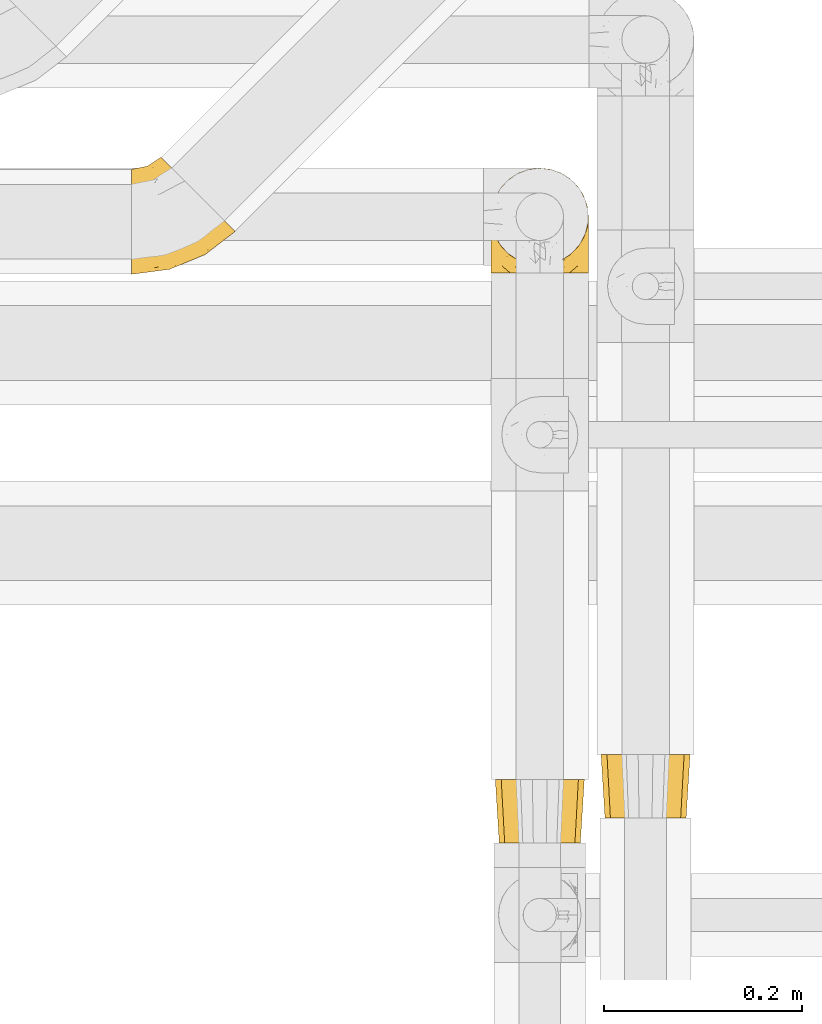
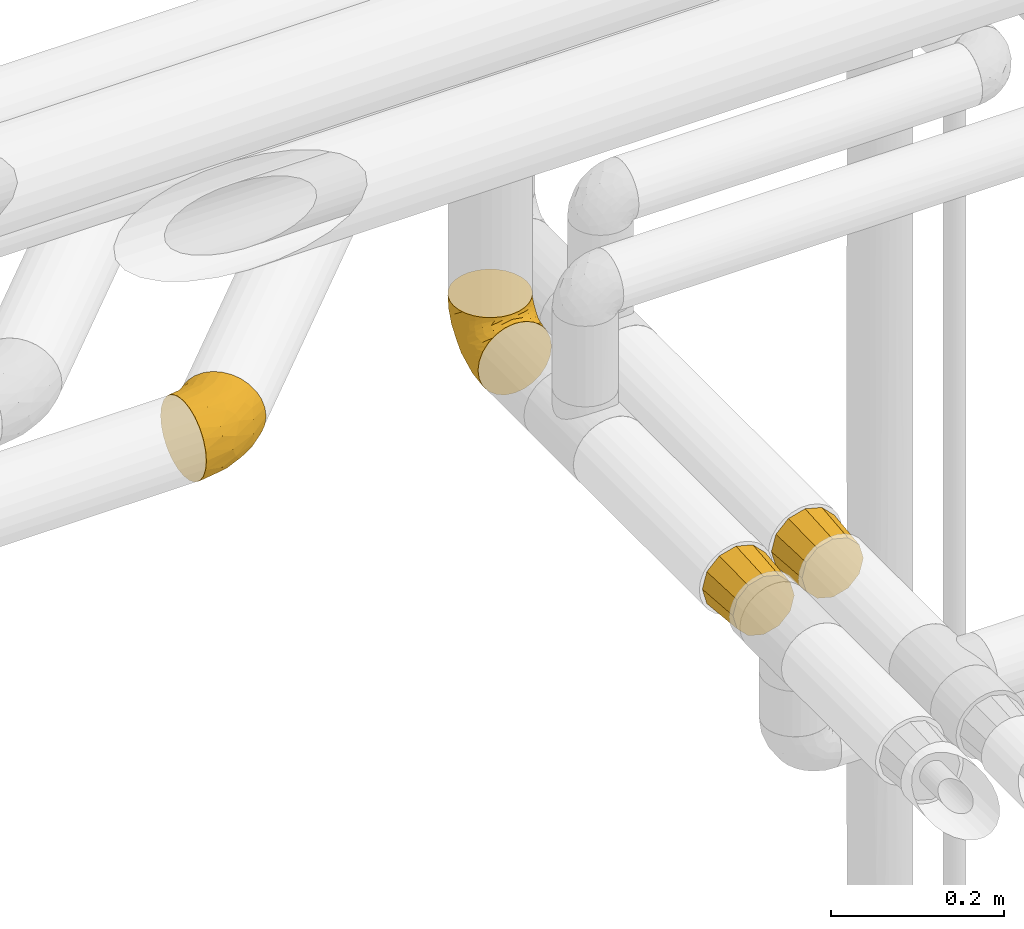
# One storey, part 371 of 827: 4 coverings.
"""IFC2X3 building model written with IfcOpenShell, lengths in millimetres."""

from ifc_helpers import new_model, entity, si_unit, converted_unit, derived_unit, direction, frame, origin, place, context, subcontext, project, spatial, faceted_brep, element, save


model = new_model("IFC2X3")

# Units and contexts
model_context = context("Model", 3, precision=0.01, world=origin(), true_north=direction((6.12303176911189e-17, 1.0)))
body_context = subcontext(model_context, "Body", "Model", "MODEL_VIEW")
ifc_project = project(units=[si_unit("LENGTHUNIT", "METRE", prefix="MILLI"), si_unit("AREAUNIT", "SQUARE_METRE"), si_unit("VOLUMEUNIT", "CUBIC_METRE"), converted_unit("PLANEANGLEUNIT", "DEGREE", entity("IfcRatioMeasure", 0.0174532925199433), si_unit("PLANEANGLEUNIT", "RADIAN"), dimensions=[0, 0, 0, 0, 0, 0, 0]), si_unit("MASSUNIT", "GRAM", prefix="KILO"), derived_unit("MASSDENSITYUNIT", [(si_unit("MASSUNIT", "GRAM", prefix="KILO"), 1), (si_unit("LENGTHUNIT", "METRE"), -3)]), derived_unit("MOMENTOFINERTIAUNIT", [(si_unit("LENGTHUNIT", "METRE"), 4)]), si_unit("TIMEUNIT", "SECOND"), si_unit("FREQUENCYUNIT", "HERTZ"), si_unit("THERMODYNAMICTEMPERATUREUNIT", "DEGREE_CELSIUS"), derived_unit("THERMALTRANSMITTANCEUNIT", [(si_unit("MASSUNIT", "GRAM", prefix="KILO"), 1), (si_unit("THERMODYNAMICTEMPERATUREUNIT", "KELVIN"), -1), (si_unit("TIMEUNIT", "SECOND"), -3)]), derived_unit("VOLUMETRICFLOWRATEUNIT", [(si_unit("LENGTHUNIT", "METRE"), 3), (si_unit("TIMEUNIT", "SECOND"), -1)]), derived_unit("MASSFLOWRATEUNIT", [(si_unit("MASSUNIT", "GRAM", prefix="KILO"), 1), (si_unit("TIMEUNIT", "SECOND"), -1)]), derived_unit("ROTATIONALFREQUENCYUNIT", [(si_unit("TIMEUNIT", "SECOND"), -1)]), si_unit("ELECTRICCURRENTUNIT", "AMPERE"), si_unit("ELECTRICVOLTAGEUNIT", "VOLT"), si_unit("POWERUNIT", "WATT"), si_unit("FORCEUNIT", "NEWTON", prefix="KILO"), si_unit("ILLUMINANCEUNIT", "LUX"), si_unit("LUMINOUSFLUXUNIT", "LUMEN"), si_unit("LUMINOUSINTENSITYUNIT", "CANDELA"), derived_unit("USERDEFINED", [(si_unit("MASSUNIT", "GRAM", prefix="KILO"), -1), (si_unit("LENGTHUNIT", "METRE"), -2), (si_unit("TIMEUNIT", "SECOND"), 3), (si_unit("LUMINOUSFLUXUNIT", "LUMEN"), 1)]), derived_unit("LINEARVELOCITYUNIT", [(si_unit("LENGTHUNIT", "METRE"), 1), (si_unit("TIMEUNIT", "SECOND"), -1)]), si_unit("PRESSUREUNIT", "PASCAL"), derived_unit("USERDEFINED", [(si_unit("LENGTHUNIT", "METRE"), -2), (si_unit("MASSUNIT", "GRAM", prefix="KILO"), 1), (si_unit("TIMEUNIT", "SECOND"), -2)]), derived_unit("LINEARFORCEUNIT", [(si_unit("MASSUNIT", "GRAM", prefix="KILO"), 1), (si_unit("LENGTHUNIT", "METRE"), 1), (si_unit("TIMEUNIT", "SECOND"), -2), (si_unit("LENGTHUNIT", "METRE"), -1)]), derived_unit("PLANARFORCEUNIT", [(si_unit("MASSUNIT", "GRAM", prefix="KILO"), 1), (si_unit("LENGTHUNIT", "METRE"), 1), (si_unit("TIMEUNIT", "SECOND"), -2), (si_unit("LENGTHUNIT", "METRE"), -2)])], contexts=[model_context])

# Site, building, storey
site_placement = place(None, origin())
site = spatial("IfcSite", under=ifc_project, at=site_placement, CompositionType="ELEMENT")
building_placement = place(site_placement, origin())
building = spatial("IfcBuilding", under=site, at=building_placement, CompositionType="ELEMENT")
storey_placement = place(building_placement, frame((0.0, 0.0, 28200.0)))
storey = spatial("IfcBuildingStorey", under=building, at=storey_placement, Name="08", CompositionType="ELEMENT", Elevation=28200.0)

# Coverings
covering_1_placement = place(storey_placement, frame((40955.41, 18876.7, 2945.35)))
element("IfcCovering", 1, at=covering_1_placement, inside=storey, Name=":ADSK_", ObjectType=":ADSK_", PredefinedType="INSULATION", context=body_context, shape_type="Brep", body=[
    faceted_brep([(39.45, 111.79, 87.73), (45.39, 105.85, 96.13), (52.5, 98.74, 102.45), (60.43, 90.81, 106.37), (68.77, 82.47, 107.7), (77.12, 74.12, 106.36), (85.05, 66.19, 102.44), (92.16, 59.08, 96.11), (98.1, 53.14, 87.71), (102.57, 48.67, 77.65), (105.34, 45.9, 66.44), (106.28, 44.96, 54.65), (105.34, 45.9, 42.84), (102.56, 48.68, 31.62), (98.09, 53.15, 21.56), (92.15, 59.09, 13.16), (85.04, 66.2, 6.84), (77.11, 74.13, 2.92), (68.77, 82.47, 1.6), (60.42, 90.82, 2.93), (52.49, 98.75, 6.85), (45.38, 105.86, 13.18), (39.44, 111.8, 21.58), (34.97, 116.27, 31.64), (32.2, 119.04, 42.85), (31.26, 119.98, 54.65), (32.2, 119.04, 66.46), (34.98, 116.26, 77.67), (1.6, 105.89, 40.91), (1.6, 100.59, 28.12), (1.6, 92.16, 17.13), (1.6, 81.17, 8.7), (1.6, 68.38, 3.4), (1.6, 54.65, 1.6), (1.6, 40.91, 3.4), (1.6, 28.12, 8.7), (1.6, 17.13, 17.13), (1.6, 8.7, 28.12), (1.6, 3.4, 40.91), (1.6, 1.6, 54.65), (1.6, 3.4, 68.38), (1.6, 8.7, 81.17), (1.6, 17.13, 92.16), (1.6, 28.12, 100.59), (1.6, 40.91, 105.89), (1.6, 54.65, 107.7), (1.6, 68.38, 105.89), (1.6, 81.17, 100.59), (1.6, 92.16, 92.16), (1.6, 100.59, 81.17), (1.6, 105.89, 68.38), (1.6, 107.7, 54.65), (72.63, 36.8, 91.31), (39.91, 6.64, 54.65), (28.07, 14.58, 86.22), (75.62, 21.43, 54.65), (46.17, 10.5, 68.84), (44.28, 46.61, 105.05), (65.61, 53.56, 103.59), (44.57, 28.19, 95.5), (45.63, 37.28, 101.06), (23.02, 35.23, 103.18), (78.63, 26.45, 71.51), (26.18, 57.88, 107.7), (14.71, 56.37, 107.7), (53.39, 24.66, 89.15), (81.53, 34.31, 82.21), (56.27, 19.92, 81.46), (69.64, 45.64, 98.88), (27.26, 8.72, 76.71), (58.28, 74.42, 107.7), (49.1, 67.37, 107.7), (37.64, 62.63, 107.7), (17.93, 82.16, 101.13), (17.26, 72.54, 105.12), (29.81, 82.64, 102.78), (47.76, 82.55, 105.93), (37.34, 74.03, 106.46), (40.73, 92.07, 101.23), (21.92, 101.94, 85.51), (18.26, 91.02, 95.32), (32.65, 98.81, 94.13), (22.95, 109.52, 73.61), (11.79, 104.28, 76.14), (14.09, 108.41, 65.55), (30.85, 108.05, 84.06), (17.65, 110.89, 54.65), (23.74, 113.23, 63.06), (11.8, 99.52, 84.51), (13.14, 108.2, 44.04), (22.95, 109.53, 35.7), (11.79, 104.28, 33.15), (32.64, 98.82, 15.18), (17.27, 72.54, 4.17), (29.8, 82.66, 6.52), (30.59, 71.32, 2.85), (11.79, 99.52, 24.78), (21.91, 101.95, 23.8), (14.71, 56.37, 1.6), (13.92, 82.39, 8.76), (18.26, 91.05, 13.99), (26.18, 57.88, 1.6), (40.73, 92.08, 8.07), (30.85, 108.06, 25.25), (47.74, 82.56, 3.36), (37.64, 62.63, 1.6), (49.1, 67.37, 1.6), (23.15, 112.78, 45.73), (58.28, 74.42, 1.6), (23.02, 35.23, 6.11), (78.63, 26.45, 37.77), (81.52, 34.32, 27.06), (72.62, 36.81, 17.97), (69.62, 45.65, 10.4), (45.63, 37.28, 8.23), (44.53, 28.17, 13.79), (28.06, 14.58, 23.07), (56.26, 19.93, 27.82), (27.25, 8.72, 32.57), (46.14, 10.49, 40.44), (65.61, 53.58, 5.69), (44.28, 46.61, 4.24)], [[[0, 1, 2, 3, 4, 5, 6, 7, 8, 9, 10, 11, 12, 13, 14, 15, 16, 17, 18, 19, 20, 21, 22, 23, 24, 25, 26, 27]], [[28, 29, 30, 31, 32, 33, 34, 35, 36, 37, 38, 39, 40, 41, 42, 43, 44, 45, 46, 47, 48, 49, 50, 51]], [[52, 8, 7]], [[40, 39, 53]], [[41, 54, 42]], [[53, 55, 56]], [[5, 57, 58]], [[59, 60, 61]], [[55, 10, 62]], [[59, 43, 42]], [[44, 63, 64, 45]], [[63, 44, 57]], [[43, 61, 44]], [[52, 65, 66]], [[54, 59, 42]], [[59, 65, 52]], [[62, 56, 55]], [[62, 67, 56]], [[52, 7, 68]], [[66, 9, 8]], [[66, 62, 9]], [[10, 55, 11]], [[54, 67, 65]], [[69, 54, 41]], [[40, 56, 69]], [[62, 66, 67]], [[68, 7, 6]], [[5, 4, 70, 71]], [[57, 71, 72, 63]], [[57, 5, 71]], [[59, 52, 68]], [[58, 68, 6]], [[60, 57, 61]], [[40, 53, 56]], [[52, 66, 8]], [[62, 10, 9]], [[40, 69, 41]], [[67, 54, 69]], [[67, 69, 56]], [[5, 58, 6]], [[60, 58, 57]], [[59, 61, 43]], [[57, 44, 61]], [[59, 68, 60]], [[58, 60, 68]], [[54, 65, 59]], [[66, 65, 67]], [[73, 48, 47]], [[63, 74, 64]], [[47, 74, 73]], [[74, 75, 73]], [[70, 76, 71]], [[75, 77, 78]], [[79, 80, 81]], [[79, 82, 83]], [[84, 51, 50]], [[49, 83, 50]], [[75, 81, 80]], [[1, 78, 2]], [[27, 85, 0]], [[82, 84, 83]], [[78, 77, 76]], [[77, 63, 72, 71]], [[85, 81, 0]], [[76, 3, 2]], [[78, 76, 2]], [[76, 70, 3]], [[77, 74, 63]], [[74, 46, 64]], [[47, 46, 74]], [[86, 87, 25]], [[86, 84, 87]], [[26, 82, 27]], [[0, 81, 1]], [[80, 88, 48]], [[79, 85, 82]], [[83, 88, 79]], [[70, 4, 3]], [[1, 81, 78]], [[81, 75, 78]], [[76, 77, 71]], [[83, 49, 88]], [[26, 87, 82]], [[51, 84, 86]], [[50, 83, 84]], [[82, 87, 84]], [[25, 87, 26]], [[82, 85, 27]], [[81, 85, 79]], [[48, 88, 49]], [[80, 79, 88]], [[46, 45, 64]], [[75, 80, 73]], [[73, 80, 48]], [[74, 77, 75]], [[89, 90, 91]], [[22, 21, 92]], [[86, 89, 51]], [[93, 94, 95]], [[96, 91, 97]], [[91, 29, 28]], [[93, 98, 32]], [[30, 99, 31]], [[93, 32, 31]], [[30, 29, 96]], [[92, 100, 97]], [[31, 99, 93]], [[93, 95, 101]], [[92, 94, 100]], [[23, 90, 24]], [[21, 102, 92]], [[23, 103, 90]], [[19, 104, 20]], [[92, 97, 103]], [[105, 101, 95, 106]], [[91, 96, 29]], [[103, 23, 22]], [[30, 100, 99]], [[104, 102, 20]], [[107, 90, 89]], [[102, 21, 20]], [[106, 104, 108]], [[104, 19, 108]], [[94, 93, 99]], [[102, 104, 94]], [[19, 18, 108]], [[107, 25, 24]], [[94, 92, 102]], [[95, 104, 106]], [[89, 91, 28]], [[97, 91, 90]], [[51, 89, 28]], [[89, 86, 107]], [[25, 107, 86]], [[24, 90, 107]], [[92, 103, 22]], [[90, 103, 97]], [[97, 100, 96]], [[30, 96, 100]], [[98, 93, 101]], [[98, 33, 32]], [[94, 99, 100]], [[104, 95, 94]], [[35, 34, 109]], [[110, 111, 13]], [[34, 33, 98, 101]], [[112, 113, 15]], [[114, 115, 109]], [[116, 115, 117]], [[39, 38, 53]], [[117, 118, 116]], [[110, 119, 117]], [[115, 116, 36]], [[35, 115, 36]], [[37, 116, 118]], [[118, 117, 119]], [[16, 120, 17]], [[121, 101, 105, 106]], [[112, 111, 117]], [[17, 106, 108, 18]], [[36, 116, 37]], [[112, 15, 14]], [[53, 38, 119]], [[117, 115, 112]], [[121, 34, 101]], [[118, 38, 37]], [[113, 16, 15]], [[119, 110, 55]], [[111, 14, 13]], [[12, 11, 55]], [[12, 55, 110]], [[120, 16, 113]], [[111, 110, 117]], [[119, 55, 53]], [[12, 110, 13]], [[111, 112, 14]], [[17, 121, 106]], [[112, 115, 113]], [[109, 115, 35]], [[38, 118, 119]], [[114, 120, 113]], [[17, 120, 121]], [[34, 121, 109]], [[109, 121, 114]], [[120, 114, 121]], [[113, 115, 114]]]),
])
for number, where, name in (
    (2, (41322.78, 18303.84, 2953.4), ":ADSK_"),
    (3, (41429.62, 18329.19, 2953.4), ":ADSK_"),
):
    element("IfcCovering", number, at=place(storey_placement, frame(where)), inside=storey, Name=name, ObjectType=":ADSK_", PredefinedType="INSULATION", context=body_context, shape_type="Brep", body=[
        faceted_brep([(11.09, 0.0, 67.1), (8.34, 0.0, 56.85), (5.6, 0.0, 46.6), (8.34, 0.0, 36.35), (11.09, 0.0, 26.1), (18.59, 0.0, 18.59), (26.1, 0.0, 11.09), (36.35, 0.0, 8.34), (46.6, 0.0, 5.6), (56.85, 0.0, 8.34), (67.1, 0.0, 11.09), (74.6, 0.0, 18.59), (82.1, 0.0, 26.1), (84.85, 0.0, 36.35), (87.6, 0.0, 46.6), (84.85, 0.0, 56.85), (82.1, 0.0, 67.1), (74.6, 0.0, 74.6), (67.1, 0.0, 82.1), (56.85, 0.0, 84.85), (46.6, 0.0, 87.6), (36.35, 0.0, 84.85), (26.1, 0.0, 82.1), (18.59, 0.0, 74.6), (91.6, 64.0, 46.6), (88.01, 64.0, 33.21), (85.57, 64.0, 24.1), (77.33, 64.0, 15.86), (69.1, 64.0, 7.62), (59.99, 64.0, 5.18), (46.6, 64.0, 1.6), (33.21, 64.0, 5.18), (24.1, 64.0, 7.62), (15.86, 64.0, 15.86), (7.62, 64.0, 24.1), (5.18, 64.0, 33.21), (1.6, 64.0, 46.6), (5.18, 64.0, 59.99), (7.62, 64.0, 69.1), (15.86, 64.0, 77.33), (24.1, 64.0, 85.57), (33.21, 64.0, 88.01), (46.6, 64.0, 91.6), (59.99, 64.0, 88.01), (69.1, 64.0, 85.57), (77.33, 64.0, 77.33), (85.57, 64.0, 69.1), (88.01, 64.0, 59.99)], [[[0, 1, 2, 3, 4, 5, 6, 7, 8, 9, 10, 11, 12, 13, 14, 15, 16, 17, 18, 19, 20, 21, 22, 23]], [[24, 25, 26, 27, 28, 29, 30, 31, 32, 33, 34, 35, 36, 37, 38, 39, 40, 41, 42, 43, 44, 45, 46, 47]], [[6, 32, 31, 30, 8, 7]], [[34, 33, 32, 6, 5, 4]], [[3, 2, 36, 35, 34, 4]], [[12, 26, 25, 24, 14, 13]], [[28, 27, 26, 12, 11, 10]], [[9, 8, 30, 29, 28, 10]], [[18, 44, 43, 42, 20, 19]], [[46, 45, 44, 18, 17, 16]], [[15, 14, 24, 47, 46, 16]], [[0, 38, 37, 36, 2, 1]], [[40, 39, 38, 0, 23, 22]], [[21, 20, 42, 41, 40, 22]]]),
    ])
covering_2_placement = place(storey_placement, frame((41318.63, 18877.87, 2949.25)))
element("IfcCovering", 4, at=covering_2_placement, inside=storey, Name=":ADSK_", ObjectType=":ADSK_", PredefinedType="INSULATION", context=body_context, shape_type="Brep", body=[
    faceted_brep([(99.9, 58.6, 107.75), (98.66, 69.54, 107.75), (95.02, 79.93, 107.75), (89.17, 89.25, 107.75), (81.38, 97.03, 107.75), (72.06, 102.88, 107.75), (61.68, 106.51, 107.75), (50.75, 107.75, 107.75), (39.8, 106.51, 107.75), (29.41, 102.87, 107.75), (20.09, 97.02, 107.75), (12.31, 89.23, 107.75), (6.46, 79.91, 107.75), (2.83, 69.53, 107.75), (1.6, 58.6, 107.75), (2.24, 52.89, 107.75), (2.83, 47.65, 107.75), (4.65, 42.46, 107.75), (6.47, 37.26, 107.75), (12.32, 27.94, 107.75), (20.11, 20.16, 107.75), (29.43, 14.31, 107.75), (39.81, 10.68, 107.75), (50.75, 9.45, 107.75), (61.69, 10.68, 107.75), (72.08, 14.32, 107.75), (81.4, 20.17, 107.75), (89.18, 27.96, 107.75), (95.03, 37.28, 107.75), (96.85, 42.47, 107.75), (98.66, 47.66, 107.75), (99.25, 52.89, 107.75), (99.57, 55.75, 107.75), (38.02, 1.6, 98.22), (26.17, 1.6, 93.31), (21.08, 1.6, 89.4), (15.99, 1.6, 85.5), (12.09, 1.6, 80.41), (8.18, 1.6, 75.32), (5.73, 1.6, 69.39), (3.27, 1.6, 63.47), (2.35, 1.6, 56.48), (1.97, 1.6, 53.61), (1.6, 1.6, 50.75), (3.27, 1.6, 38.02), (8.18, 1.6, 26.17), (15.99, 1.6, 15.99), (26.17, 1.6, 8.18), (38.02, 1.6, 3.27), (50.75, 1.6, 1.6), (63.47, 1.6, 3.27), (75.32, 1.6, 8.18), (85.5, 1.6, 15.99), (93.31, 1.6, 26.17), (98.22, 1.6, 38.02), (99.9, 1.6, 50.75), (99.14, 1.6, 56.48), (98.22, 1.6, 63.47), (95.77, 1.6, 69.39), (93.31, 1.6, 75.32), (89.4, 1.6, 80.41), (85.5, 1.6, 85.5), (80.41, 1.6, 89.4), (75.32, 1.6, 93.31), (63.47, 1.6, 98.22), (50.75, 1.6, 99.9), (59.31, 69.96, 27.53), (73.08, 59.59, 25.32), (63.72, 51.96, 16.29), (50.75, 34.4, 6.79), (58.64, 23.37, 4.51), (50.75, 13.68, 3.51), (76.74, 41.52, 17.47), (67.68, 26.26, 7.6), (78.92, 20.18, 12.27), (94.31, 72.33, 70.89), (98.76, 65.88, 87.17), (98.4, 57.55, 67.3), (94.57, 23.76, 31.65), (89.91, 46.5, 33.58), (96.32, 46.57, 47.23), (98.79, 21.17, 43.26), (99.9, 23.41, 55.08), (99.9, 17.92, 53.99), (99.9, 12.43, 52.9), (99.9, 9.72, 52.36), (99.9, 7.01, 51.82), (87.31, 26.77, 21.5), (95.61, 76.59, 89.94), (60.43, 95.55, 60.45), (65.24, 102.57, 83.0), (72.87, 92.89, 64.79), (99.9, 54.26, 85.93), (99.9, 51.17, 81.31), (99.9, 48.08, 76.69), (99.9, 44.99, 72.06), (99.9, 41.9, 67.44), (90.65, 85.16, 88.74), (63.14, 85.97, 45.98), (91.89, 59.58, 47.13), (75.25, 99.5, 89.4), (50.75, 105.83, 95.66), (82.18, 53.59, 28.5), (85.08, 67.0, 42.81), (76.93, 71.56, 38.28), (50.75, 87.47, 45.35), (50.75, 75.73, 33.61), (83.02, 92.24, 82.57), (99.9, 58.06, 105.04), (99.9, 57.52, 102.33), (99.9, 56.44, 96.91), (99.9, 55.35, 91.42), (87.13, 81.33, 65.92), (80.85, 80.35, 53.11), (99.17, 39.44, 54.37), (50.75, 102.55, 74.94), (99.9, 37.28, 64.35), (99.9, 32.65, 61.26), (99.9, 28.03, 58.17), (50.75, 63.99, 21.87), (67.61, 74.55, 34.79), (72.25, 83.62, 48.48), (50.75, 95.01, 60.15), (50.75, 49.19, 14.33), (98.69, 46.96, 99.07), (99.01, 8.77, 60.55), (98.79, 18.28, 64.18), (98.29, 11.68, 64.36), (68.51, 11.79, 103.17), (76.82, 15.69, 101.69), (98.54, 42.49, 87.75), (99.3, 47.41, 89.38), (83.57, 7.94, 88.34), (89.47, 9.27, 82.14), (75.76, 7.98, 94.51), (84.86, 13.4, 89.64), (75.89, 13.04, 98.41), (64.77, 7.36, 99.71), (90.83, 23.46, 89.37), (94.62, 30.46, 88.21), (90.37, 26.54, 95.2), (91.18, 6.76, 79.14), (88.65, 26.46, 101.22), (84.11, 20.77, 99.41), (91.75, 20.68, 84.72), (96.86, 40.26, 97.47), (50.75, 7.15, 102.19), (58.97, 9.28, 104.02), (98.37, 38.78, 82.66), (83.91, 18.27, 95.42), (97.52, 31.78, 78.67), (95.55, 12.75, 72.69), (98.76, 22.96, 66.46), (95.26, 17.55, 75.3), (98.04, 27.63, 72.74), (90.65, 15.23, 82.93), (93.51, 33.25, 99.27), (94.16, 32.43, 93.51), (99.1, 27.9, 67.35), (25.73, 7.97, 94.51), (10.84, 15.22, 82.94), (17.92, 7.93, 88.33), (16.64, 13.38, 89.64), (30.44, 13.12, 103.62), (2.95, 42.49, 87.74), (2.19, 47.4, 89.38), (1.6, 51.17, 81.31), (4.63, 40.24, 97.47), (17.39, 20.76, 99.41), (1.6, 12.43, 52.9), (1.6, 7.01, 51.82), (1.6, 4.31, 51.28), (12.86, 26.44, 101.21), (11.13, 26.52, 95.19), (3.2, 11.68, 64.36), (5.94, 12.75, 72.69), (12.02, 9.27, 82.13), (6.23, 17.55, 75.3), (10.31, 6.76, 79.14), (8.0, 33.21, 99.28), (7.34, 32.41, 93.51), (2.48, 8.77, 60.55), (2.73, 22.96, 66.46), (2.64, 18.48, 63.96), (1.6, 56.44, 96.91), (2.8, 46.95, 99.06), (36.71, 7.36, 99.7), (1.6, 17.92, 53.99), (1.6, 23.41, 55.08), (38.59, 9.85, 103.3), (1.6, 57.52, 102.33), (1.6, 56.98, 99.62), (1.6, 48.08, 76.69), (3.12, 38.78, 82.66), (17.59, 18.25, 95.42), (1.6, 44.99, 72.06), (3.98, 31.74, 78.68), (6.87, 30.45, 88.2), (3.45, 27.63, 72.75), (9.76, 20.65, 84.74), (1.6, 55.35, 91.42), (1.6, 54.26, 85.93), (25.62, 13.03, 98.41), (10.67, 23.44, 89.37), (2.39, 27.9, 67.35), (1.6, 32.65, 61.26), (1.6, 28.03, 58.17), (1.6, 37.28, 64.35), (1.6, 41.9, 67.44), (2.4, 39.74, 54.08), (42.85, 23.37, 4.51), (14.18, 26.77, 21.5), (11.56, 46.18, 33.43), (19.27, 53.54, 28.5), (24.75, 41.53, 17.47), (28.37, 59.61, 25.36), (5.95, 76.79, 90.18), (2.79, 66.11, 86.97), (2.71, 21.17, 43.26), (37.78, 51.96, 16.29), (33.81, 26.26, 7.6), (22.57, 20.18, 12.27), (6.92, 23.76, 31.65), (28.61, 92.88, 64.79), (36.24, 102.57, 83.0), (41.05, 95.54, 60.44), (24.55, 71.63, 38.35), (33.88, 74.55, 34.8), (7.11, 72.51, 71.54), (42.18, 69.96, 27.53), (18.46, 92.23, 82.57), (10.84, 85.15, 88.74), (20.69, 80.45, 53.19), (29.27, 83.65, 48.49), (3.1, 57.57, 67.28), (9.18, 63.68, 52.32), (38.38, 85.95, 45.94), (26.23, 99.49, 89.4), (14.34, 81.23, 65.75), (5.46, 47.07, 46.73), (16.39, 66.99, 42.82)], [[[0, 1, 2, 3, 4, 5, 6, 7, 8, 9, 10, 11, 12, 13, 14, 15, 16, 17, 18, 19, 20, 21, 22, 23, 24, 25, 26, 27, 28, 29, 30, 31, 32]], [[33, 34, 35, 36, 37, 38, 39, 40, 41, 42, 43, 44, 45, 46, 47, 48, 49, 50, 51, 52, 53, 54, 55, 56, 57, 58, 59, 60, 61, 62, 63, 64, 65]], [[66, 67, 68]], [[69, 70, 71]], [[68, 72, 73]], [[73, 72, 74]], [[75, 76, 77]], [[78, 79, 80]], [[51, 50, 73]], [[81, 82, 83, 84, 85, 86, 55]], [[52, 87, 53]], [[74, 52, 51]], [[2, 1, 88]], [[89, 90, 91]], [[77, 92, 93, 94, 95, 96]], [[55, 54, 81]], [[78, 53, 87]], [[5, 90, 6]], [[88, 76, 75]], [[97, 3, 2]], [[89, 91, 98]], [[99, 80, 79]], [[90, 5, 100]], [[74, 87, 52]], [[100, 5, 4]], [[90, 101, 6]], [[79, 102, 103]], [[102, 67, 104]], [[105, 98, 106]], [[107, 4, 3]], [[76, 0, 108, 109, 110, 111, 92]], [[107, 112, 113]], [[114, 77, 96]], [[89, 115, 90]], [[114, 96, 116, 117, 118, 82]], [[75, 97, 88]], [[119, 66, 68]], [[50, 71, 70]], [[100, 91, 90]], [[99, 77, 80]], [[102, 104, 103]], [[97, 107, 3]], [[80, 81, 78]], [[107, 97, 112]], [[68, 73, 70]], [[66, 98, 120]], [[78, 81, 54]], [[114, 81, 80]], [[53, 78, 54]], [[78, 87, 79]], [[102, 87, 72]], [[79, 103, 99]], [[4, 107, 100]], [[91, 100, 107]], [[88, 97, 2]], [[112, 97, 75]], [[99, 112, 75]], [[103, 104, 113]], [[91, 121, 98]], [[89, 105, 122, 115]], [[101, 90, 115]], [[101, 7, 6]], [[88, 1, 76]], [[0, 76, 1]], [[92, 77, 76]], [[73, 74, 51]], [[87, 74, 72]], [[81, 114, 82]], [[77, 114, 80]], [[87, 102, 79]], [[67, 102, 72]], [[68, 67, 72]], [[67, 120, 104]], [[120, 121, 104]], [[104, 121, 113]], [[121, 120, 98]], [[91, 107, 113]], [[91, 113, 121]], [[103, 113, 112]], [[106, 98, 66]], [[105, 89, 98]], [[106, 66, 119]], [[67, 66, 120]], [[68, 69, 123, 119]], [[50, 49, 71]], [[50, 70, 73]], [[112, 99, 103]], [[77, 99, 75]], [[69, 68, 70]], [[29, 124, 110]], [[84, 83, 125]], [[126, 82, 118]], [[59, 58, 127]], [[25, 128, 129]], [[130, 93, 131]], [[132, 62, 133]], [[134, 135, 136]], [[137, 65, 64]], [[64, 134, 137]], [[138, 139, 140]], [[111, 110, 124, 92]], [[134, 136, 137]], [[134, 64, 63]], [[141, 61, 60]], [[125, 58, 57]], [[142, 143, 140]], [[142, 26, 143]], [[127, 83, 82]], [[28, 124, 29]], [[108, 0, 32, 31, 30, 110, 109]], [[30, 29, 110]], [[135, 144, 138]], [[28, 145, 124]], [[57, 56, 55, 86, 85, 84]], [[146, 147, 23]], [[24, 23, 147]], [[25, 143, 26]], [[95, 94, 148]], [[24, 128, 25]], [[149, 138, 143]], [[124, 145, 131]], [[127, 58, 125]], [[150, 148, 139]], [[127, 126, 151]], [[151, 59, 127]], [[152, 151, 126]], [[153, 154, 155]], [[153, 133, 141]], [[145, 28, 27]], [[142, 156, 27]], [[157, 148, 130]], [[61, 133, 62]], [[134, 132, 135]], [[147, 128, 24]], [[65, 137, 146]], [[146, 137, 147]], [[128, 137, 136]], [[137, 128, 147]], [[128, 136, 129]], [[149, 129, 136]], [[25, 129, 143]], [[158, 152, 117]], [[152, 118, 117]], [[153, 151, 152]], [[158, 116, 154]], [[144, 150, 138]], [[153, 152, 158]], [[133, 153, 155]], [[133, 155, 132]], [[60, 151, 141]], [[135, 132, 155]], [[134, 63, 132]], [[144, 135, 155]], [[135, 138, 149]], [[155, 154, 144]], [[150, 154, 96]], [[154, 150, 144]], [[148, 94, 130]], [[82, 126, 127]], [[118, 152, 126]], [[150, 96, 95]], [[139, 148, 157]], [[150, 95, 148]], [[93, 92, 131]], [[130, 145, 156]], [[130, 94, 93]], [[84, 125, 57]], [[127, 125, 83]], [[140, 139, 157]], [[150, 139, 138]], [[140, 157, 142]], [[138, 140, 143]], [[156, 142, 157]], [[27, 26, 142]], [[130, 156, 157]], [[145, 27, 156]], [[132, 63, 62]], [[124, 131, 92]], [[130, 131, 145]], [[129, 149, 143]], [[135, 149, 136]], [[141, 133, 61]], [[60, 59, 151]], [[141, 151, 153]], [[116, 96, 154]], [[153, 158, 154]], [[158, 117, 116]], [[34, 33, 159]], [[160, 161, 162]], [[22, 21, 163]], [[164, 165, 166]], [[19, 18, 167]], [[168, 21, 20]], [[42, 41, 40, 169, 170, 171, 43]], [[172, 173, 168]], [[174, 38, 175]], [[176, 177, 178]], [[179, 164, 180]], [[40, 181, 169]], [[182, 183, 175]], [[17, 184, 185]], [[65, 146, 186]], [[187, 174, 188]], [[23, 22, 189]], [[174, 39, 38]], [[15, 14, 190, 191, 184, 16]], [[181, 40, 39]], [[192, 193, 164]], [[194, 163, 168]], [[33, 186, 159]], [[180, 173, 172]], [[195, 196, 193]], [[18, 185, 167]], [[173, 180, 197]], [[198, 199, 196]], [[200, 201, 185, 184]], [[184, 17, 16]], [[18, 17, 185]], [[202, 159, 186]], [[194, 168, 203]], [[189, 163, 202]], [[204, 205, 182]], [[187, 181, 174]], [[160, 177, 176]], [[206, 183, 182]], [[206, 182, 205]], [[201, 165, 185]], [[165, 164, 167]], [[172, 179, 180]], [[202, 194, 162]], [[176, 161, 160]], [[65, 186, 33]], [[163, 189, 22]], [[175, 177, 182]], [[174, 183, 188]], [[177, 198, 204]], [[199, 160, 162]], [[198, 207, 204]], [[175, 38, 37]], [[198, 177, 160]], [[178, 177, 175]], [[176, 35, 161]], [[34, 159, 161]], [[162, 161, 159]], [[202, 162, 159]], [[199, 162, 203]], [[196, 199, 203]], [[198, 160, 199]], [[193, 197, 180]], [[208, 198, 196]], [[188, 183, 206]], [[175, 183, 174]], [[193, 192, 195]], [[195, 208, 196]], [[197, 196, 203]], [[180, 164, 193]], [[168, 163, 21]], [[166, 165, 201]], [[166, 192, 164]], [[189, 202, 186]], [[186, 146, 189]], [[23, 189, 146]], [[174, 181, 39]], [[169, 181, 187]], [[196, 197, 193]], [[173, 203, 168]], [[203, 173, 197]], [[172, 168, 20]], [[20, 19, 172]], [[179, 172, 19]], [[19, 167, 179]], [[164, 179, 167]], [[35, 176, 36]], [[35, 34, 161]], [[185, 165, 167]], [[162, 194, 203]], [[163, 194, 202]], [[176, 178, 36]], [[37, 36, 178]], [[175, 37, 178]], [[177, 204, 182]], [[207, 198, 208]], [[207, 205, 204]], [[209, 188, 206, 205, 207, 208]], [[48, 210, 71]], [[211, 212, 213]], [[214, 213, 215]], [[216, 217, 13]], [[218, 43, 171, 170, 169, 187, 188]], [[219, 220, 214]], [[47, 46, 221]], [[210, 48, 220]], [[211, 222, 212]], [[222, 45, 44]], [[221, 220, 47]], [[47, 220, 48]], [[221, 211, 214]], [[223, 224, 225]], [[211, 46, 45]], [[226, 227, 215]], [[43, 218, 44]], [[217, 216, 228]], [[219, 215, 229]], [[14, 13, 217]], [[224, 9, 8]], [[10, 230, 11]], [[11, 231, 12]], [[232, 223, 233]], [[234, 208, 195, 192, 166, 201]], [[235, 234, 228]], [[222, 44, 218]], [[106, 229, 236]], [[224, 237, 9]], [[231, 238, 228]], [[9, 237, 10]], [[115, 224, 101]], [[239, 234, 235]], [[231, 11, 230]], [[223, 230, 237]], [[224, 8, 101]], [[223, 236, 233]], [[225, 115, 122, 105]], [[216, 12, 231]], [[209, 234, 239]], [[210, 219, 69]], [[219, 214, 215]], [[229, 119, 219]], [[209, 218, 188]], [[239, 212, 222]], [[239, 222, 218]], [[45, 222, 211]], [[235, 212, 239]], [[213, 212, 240]], [[223, 237, 224]], [[230, 10, 237]], [[238, 231, 230]], [[216, 231, 228]], [[232, 230, 223]], [[235, 238, 240]], [[115, 225, 224]], [[233, 236, 227]], [[8, 7, 101]], [[234, 209, 208]], [[218, 209, 239]], [[217, 228, 234]], [[13, 12, 216]], [[234, 201, 217]], [[217, 201, 200, 184, 191, 190, 14]], [[211, 221, 46]], [[220, 221, 214]], [[71, 210, 69]], [[71, 49, 48]], [[219, 210, 220]], [[226, 215, 213]], [[211, 213, 214]], [[226, 213, 240]], [[215, 227, 229]], [[232, 240, 238]], [[233, 227, 226]], [[232, 233, 226]], [[236, 223, 225]], [[240, 232, 226]], [[232, 238, 230]], [[225, 105, 236]], [[236, 105, 106]], [[236, 229, 227]], [[123, 69, 219, 119]], [[106, 119, 229]], [[238, 235, 228]], [[212, 235, 240]]]),
])

save(model, "model.ifc")
